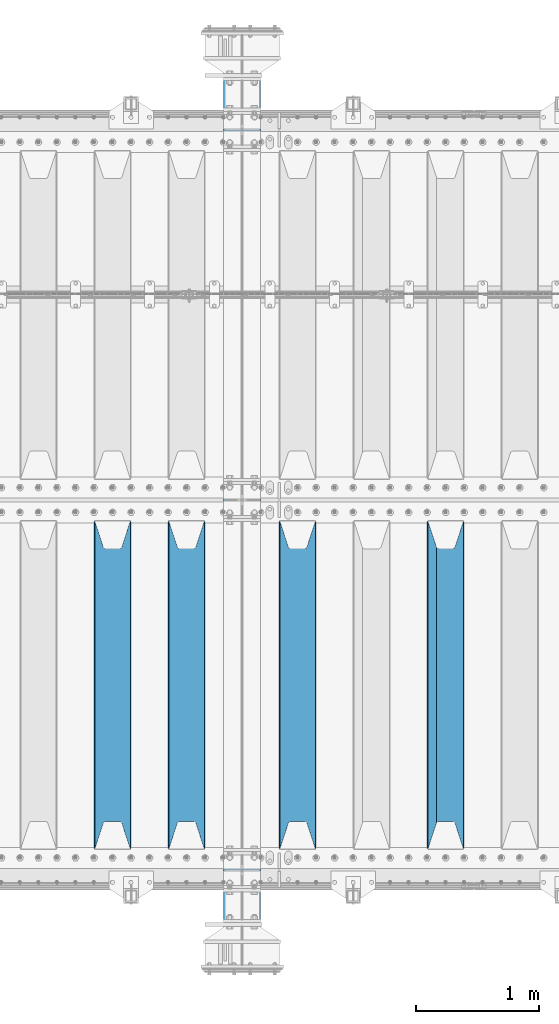
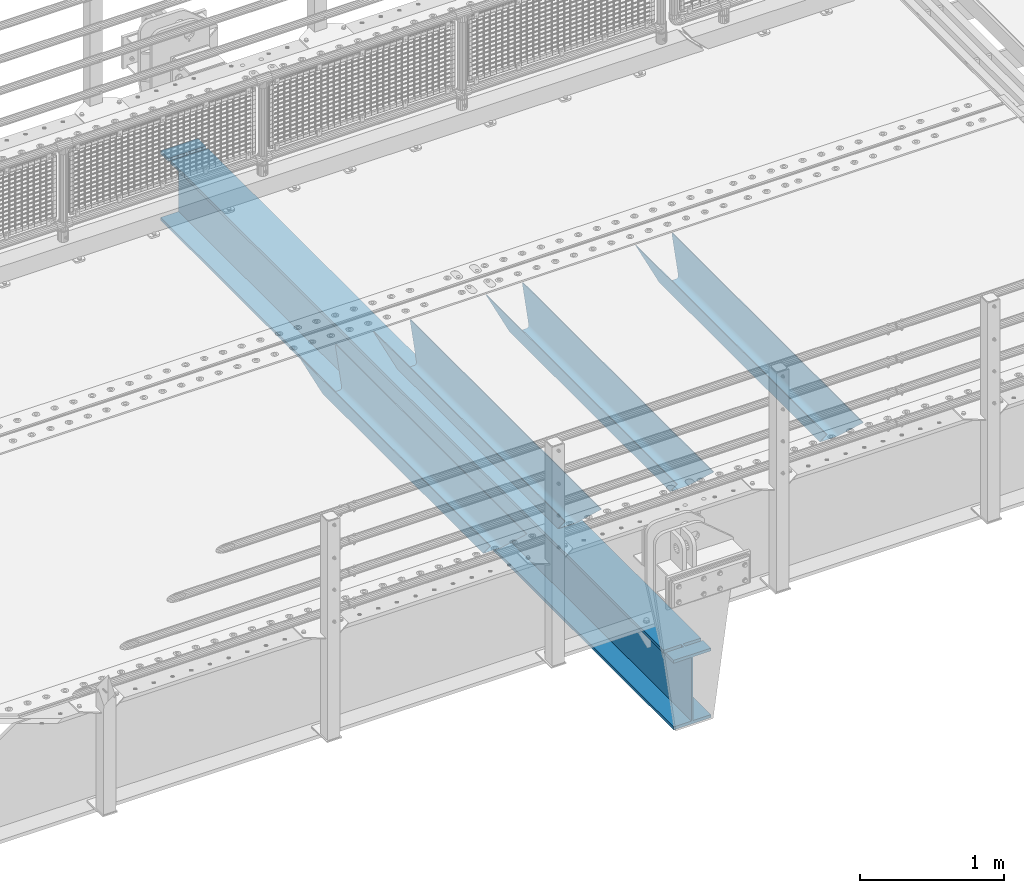
# One storey, part 101 of 208: 5 beams.
"""IFC2X3 building model written with IfcOpenShell, lengths in millimetres."""

from ifc_helpers import new_model, si_unit, frame, origin_with_axes, place, context, subcontext, project, spatial, faceted_brep, material, type_object, element, save


model = new_model("IFC2X3")

# Units and contexts
model_context = context("Model", 3, precision=1e-05, world=origin_with_axes())
body_context = subcontext(model_context, "Body", "Model", "MODEL_VIEW")
ifc_project = project(units=[si_unit("LENGTHUNIT", "METRE", prefix="MILLI"), si_unit("AREAUNIT", "SQUARE_METRE"), si_unit("VOLUMEUNIT", "CUBIC_METRE"), si_unit("MASSUNIT", "GRAM", prefix="KILO"), si_unit("TIMEUNIT", "SECOND"), si_unit("PLANEANGLEUNIT", "RADIAN"), si_unit("SOLIDANGLEUNIT", "STERADIAN"), si_unit("THERMODYNAMICTEMPERATUREUNIT", "DEGREE_CELSIUS"), si_unit("LUMINOUSINTENSITYUNIT", "LUMEN")], contexts=[model_context])

# Site, building, storey
site_placement = place(None, origin_with_axes())
site = spatial("IfcSite", under=ifc_project, at=site_placement, CompositionType="ELEMENT")
building_placement = place(site_placement, origin_with_axes())
building = spatial("IfcBuilding", under=site, at=building_placement, Name="Standard", CompositionType="ELEMENT")
storey_placement = place(building_placement, origin_with_axes())
storey = spatial("IfcBuildingStorey", under=building, at=storey_placement, Name="Undefined", CompositionType="ELEMENT", Elevation=0.0)

# Beams
ifc_material = material(Name="STEEL/S355N")
beam_type_1 = type_object("IfcBeamType", PredefinedType="NOTDEFINED")
beam_1_placement = place(storey_placement, frame((-28550.0, 175.0, -115.0), z_axis=(0.0, 0.0, 1.0), x_axis=(0.0, 1.0, 0.0)))
element("IfcBeam", 1, at=beam_1_placement, inside=storey, type_object=beam_type_1, material=ifc_material, context=body_context, shape_type="Brep", body=[
    faceted_brep([(0.0, 150.0, 115.0), (0.0, 143.689999999999, 115.0), (2650.00000000297, 143.689999999999, 115.0), (2650.00000000297, 150.0, 115.0), (2650.00000000297, 142.059565218402, 110.0000000031), (2650.00000000297, 148.369565218403, 110.0000000031), (2441.90079219208, -80.1103600731112, -98.0992078077845), (2437.7588105432, -77.5672621345584, -102.241189456673), (2434.06523489746, -74.4080125315522, -105.934765102404), (2430.91086095089, -70.710272125576, -109.089139048974), (2428.37322971128, -66.5649389910068, -111.626770288588), (2426.51472138055, -62.0739139532889, -113.485278619323), (2425.38102192091, -57.3475956567672, -114.618978078955), (2424.99999999987, -52.5021667386536, -115.0), (2424.99999999987, 52.5021667386536, -115.0), (2425.38102192091, 57.3475956567672, -114.618978078955), (2426.51472138055, 62.0739139532889, -113.485278619323), (2428.37322971128, 66.5649389910068, -111.626770288588), (2430.91086095089, 70.710272125576, -109.089139048974), (2434.06523489746, 74.4080125315522, -105.934765102404), (2437.7588105432, 77.5672621345584, -102.241189456673), (2441.90079219208, 80.1103600731112, -98.0992078077846), (2446.38936140511, 81.9747917625791, -93.6106385947584), (2448.24948500409, 76.2713538057251, -91.7505149957729), (2444.62967112262, 74.76777986261, -95.3703288772456), (2441.28936334126, 72.7168944282894, -98.710636658607), (2438.31067330438, 70.1691124903846, -101.689326695487), (2435.76682334747, 67.1870637758839, -104.233176652398), (2433.72034654133, 63.8440531834895, -106.279653458539), (2432.22154950041, 60.222258798236, -107.778450499454), (2431.30727574265, 56.4107117849089, -108.692724257221), (2430.99999999987, 52.5031078186876, -109.0), (2430.99999999987, -52.5031078186876, -109.0), (2431.30727574265, -56.4107117849089, -108.692724257221), (2432.22154950041, -60.222258798236, -107.778450499454), (2433.72034654133, -63.8440531834895, -106.279653458539), (2435.76682334747, -67.1870637758839, -104.233176652398), (2438.31067330438, -70.1691124903846, -101.689326695487), (2441.28936334126, -72.7168944282894, -98.7106366586071), (2444.62967112262, -74.76777986261, -95.3703288772457), (2448.24948500409, -76.2713538057251, -91.7505149957729), (2650.00000000297, -142.059565218402, 110.0000000031), (2650.00000000297, -148.369565218403, 110.0000000031), (2446.38936140511, -81.9747917625791, -93.6106385947584), (2650.00000000297, -143.689999999999, 115.0), (2650.00000000297, -150.0, 115.0), (0.0, -143.689999999999, 115.0), (0.0, -150.0, 115.0), (0.0, -148.369565218261, 110.000000002663), (203.610638597421, -81.9747917625791, -93.6106385947584), (208.099207810448, -80.1103600731112, -98.0992078077845), (212.241189459336, -77.5672621345584, -102.241189456673), (215.934765105067, -74.4080125315522, -105.934765102404), (219.089139051637, -70.710272125576, -109.089139048974), (221.626770291251, -66.5649389910068, -111.626770288588), (223.485278621986, -62.0739139532889, -113.485278619323), (224.618978081618, -57.3475956567672, -114.618978078955), (225.000000002663, -52.5021667386536, -115.0), (225.000000002663, 52.5021667386536, -115.0), (224.618978081618, 57.3475956567672, -114.618978078955), (223.485278621986, 62.0739139532889, -113.485278619323), (221.626770291251, 66.5649389910068, -111.626770288588), (219.089139051637, 70.710272125576, -109.089139048974), (215.934765105067, 74.4080125315522, -105.934765102404), (212.241189459336, 77.5672621345584, -102.241189456673), (208.099207810448, 80.1103600731112, -98.0992078077846), (203.610638597421, 81.9747917625791, -93.6106385947584), (0.0, 148.369565218261, 110.000000002663), (0.0, 142.05956521826, 110.000000002663), (201.750514998436, 76.2713538057251, -91.7505149957729), (205.370328879908, 74.76777986261, -95.3703288772456), (208.71063666127, 72.7168944282894, -98.710636658607), (211.68932669815, 70.1691124903846, -101.689326695487), (214.233176655061, 67.1870637758839, -104.233176652398), (216.279653461202, 63.8440531834895, -106.279653458539), (217.778450502116, 60.222258798236, -107.778450499454), (218.692724259884, 56.4107117849089, -108.692724257221), (219.000000002663, 52.5031078186876, -109.0), (219.000000002663, -52.5031078186876, -109.0), (218.692724259884, -56.4107117849089, -108.692724257221), (217.778450502116, -60.222258798236, -107.778450499454), (216.279653461202, -63.8440531834895, -106.279653458539), (214.233176655061, -67.1870637758839, -104.233176652398), (211.68932669815, -70.1691124903846, -101.689326695487), (208.71063666127, -72.7168944282894, -98.7106366586071), (205.370328879908, -74.76777986261, -95.3703288772457), (201.750514998436, -76.2713538057251, -91.7505149957729), (0.0, -142.05956521826, 110.000000002663)], [[[0, 1, 2, 3]], [[3, 2, 4, 5]], [[6, 7, 8, 9, 10, 11, 12, 13, 14, 15, 16, 17, 18, 19, 20, 21, 22, 5, 4, 23, 24, 25, 26, 27, 28, 29, 30, 31, 32, 33, 34, 35, 36, 37, 38, 39, 40, 41, 42, 43]], [[44, 45, 42, 41]], [[46, 47, 45, 44]], [[43, 42, 45, 47, 48, 49]], [[6, 43, 49, 50]], [[7, 6, 50, 51]], [[8, 7, 51, 52]], [[9, 8, 52, 53]], [[10, 9, 53, 54]], [[11, 10, 54, 55]], [[12, 11, 55, 56]], [[13, 12, 56, 57]], [[14, 13, 57, 58]], [[15, 14, 58, 59]], [[16, 15, 59, 60]], [[17, 16, 60, 61]], [[18, 17, 61, 62]], [[19, 18, 62, 63]], [[20, 19, 63, 64]], [[21, 20, 64, 65]], [[22, 21, 65, 66]], [[0, 3, 5, 22, 66, 67]], [[1, 0, 67, 68]], [[23, 4, 2, 1, 68, 69]], [[24, 23, 69, 70]], [[25, 24, 70, 71]], [[26, 25, 71, 72]], [[27, 26, 72, 73]], [[28, 27, 73, 74]], [[29, 28, 74, 75]], [[30, 29, 75, 76]], [[31, 30, 76, 77]], [[32, 31, 77, 78]], [[33, 32, 78, 79]], [[34, 33, 79, 80]], [[35, 34, 80, 81]], [[36, 35, 81, 82]], [[37, 36, 82, 83]], [[38, 37, 83, 84]], [[39, 38, 84, 85]], [[40, 39, 85, 86]], [[46, 44, 41, 40, 86, 87]], [[47, 46, 87, 48]], [[86, 85, 84, 83, 82, 81, 80, 79, 78, 77, 76, 75, 74, 73, 72, 71, 70, 69, 68, 67, 66, 65, 64, 63, 62, 61, 60, 59, 58, 57, 56, 55, 54, 53, 52, 51, 50, 49, 48, 87]]]),
])
beam_2_placement = place(storey_placement, frame((-29750.0, 175.0, -115.0), z_axis=(0.0, 0.0, 1.0), x_axis=(0.0, 1.0, 0.0)))
element("IfcBeam", 2, at=beam_2_placement, inside=storey, type_object=beam_type_1, material=ifc_material, context=body_context, shape_type="Brep", body=[
    faceted_brep([(0.0, 150.0, 115.0), (0.0, 143.689999999999, 115.0), (2650.00000000297, 143.689999999999, 115.0), (2650.00000000297, 150.0, 115.0), (2650.00000000297, 142.059565218402, 110.0000000031), (2650.00000000297, 148.369565218403, 110.0000000031), (2441.90079219208, -80.1103600731112, -98.0992078077845), (2437.7588105432, -77.5672621345584, -102.241189456673), (2434.06523489746, -74.4080125315522, -105.934765102404), (2430.91086095089, -70.710272125576, -109.089139048974), (2428.37322971128, -66.5649389910068, -111.626770288588), (2426.51472138055, -62.0739139532889, -113.485278619323), (2425.38102192091, -57.3475956567672, -114.618978078955), (2424.99999999987, -52.5021667386536, -115.0), (2424.99999999987, 52.5021667386536, -115.0), (2425.38102192091, 57.3475956567672, -114.618978078955), (2426.51472138055, 62.0739139532889, -113.485278619323), (2428.37322971128, 66.5649389910068, -111.626770288588), (2430.91086095089, 70.710272125576, -109.089139048974), (2434.06523489746, 74.4080125315522, -105.934765102404), (2437.7588105432, 77.5672621345584, -102.241189456673), (2441.90079219208, 80.1103600731112, -98.0992078077846), (2446.38936140511, 81.9747917625791, -93.6106385947584), (2448.24948500409, 76.2713538057251, -91.7505149957729), (2444.62967112262, 74.76777986261, -95.3703288772456), (2441.28936334126, 72.7168944282894, -98.710636658607), (2438.31067330438, 70.1691124903846, -101.689326695487), (2435.76682334747, 67.1870637758839, -104.233176652398), (2433.72034654133, 63.8440531834895, -106.279653458539), (2432.22154950041, 60.222258798236, -107.778450499454), (2431.30727574265, 56.4107117849089, -108.692724257221), (2430.99999999987, 52.5031078186876, -109.0), (2430.99999999987, -52.5031078186876, -109.0), (2431.30727574265, -56.4107117849089, -108.692724257221), (2432.22154950041, -60.222258798236, -107.778450499454), (2433.72034654133, -63.8440531834895, -106.279653458539), (2435.76682334747, -67.1870637758839, -104.233176652398), (2438.31067330438, -70.1691124903846, -101.689326695487), (2441.28936334126, -72.7168944282894, -98.7106366586071), (2444.62967112262, -74.76777986261, -95.3703288772457), (2448.24948500409, -76.2713538057251, -91.7505149957729), (2650.00000000297, -142.059565218402, 110.0000000031), (2650.00000000297, -148.369565218403, 110.0000000031), (2446.38936140511, -81.9747917625791, -93.6106385947584), (2650.00000000297, -143.689999999999, 115.0), (2650.00000000297, -150.0, 115.0), (0.0, -143.689999999999, 115.0), (0.0, -150.0, 115.0), (0.0, -148.369565218261, 110.000000002663), (203.610638597421, -81.9747917625791, -93.6106385947584), (208.099207810448, -80.1103600731112, -98.0992078077845), (212.241189459336, -77.5672621345584, -102.241189456673), (215.934765105067, -74.4080125315522, -105.934765102404), (219.089139051637, -70.710272125576, -109.089139048974), (221.626770291251, -66.5649389910068, -111.626770288588), (223.485278621986, -62.0739139532889, -113.485278619323), (224.618978081618, -57.3475956567672, -114.618978078955), (225.000000002663, -52.5021667386536, -115.0), (225.000000002663, 52.5021667386536, -115.0), (224.618978081618, 57.3475956567672, -114.618978078955), (223.485278621986, 62.0739139532889, -113.485278619323), (221.626770291251, 66.5649389910068, -111.626770288588), (219.089139051637, 70.710272125576, -109.089139048974), (215.934765105067, 74.4080125315522, -105.934765102404), (212.241189459336, 77.5672621345584, -102.241189456673), (208.099207810448, 80.1103600731112, -98.0992078077846), (203.610638597421, 81.9747917625791, -93.6106385947584), (0.0, 148.369565218261, 110.000000002663), (0.0, 142.05956521826, 110.000000002663), (201.750514998436, 76.2713538057251, -91.7505149957729), (205.370328879908, 74.76777986261, -95.3703288772456), (208.71063666127, 72.7168944282894, -98.710636658607), (211.68932669815, 70.1691124903846, -101.689326695487), (214.233176655061, 67.1870637758839, -104.233176652398), (216.279653461202, 63.8440531834895, -106.279653458539), (217.778450502116, 60.222258798236, -107.778450499454), (218.692724259884, 56.4107117849089, -108.692724257221), (219.000000002663, 52.5031078186876, -109.0), (219.000000002663, -52.5031078186876, -109.0), (218.692724259884, -56.4107117849089, -108.692724257221), (217.778450502116, -60.222258798236, -107.778450499454), (216.279653461202, -63.8440531834895, -106.279653458539), (214.233176655061, -67.1870637758839, -104.233176652398), (211.68932669815, -70.1691124903846, -101.689326695487), (208.71063666127, -72.7168944282894, -98.7106366586071), (205.370328879908, -74.76777986261, -95.3703288772457), (201.750514998436, -76.2713538057251, -91.7505149957729), (0.0, -142.05956521826, 110.000000002663)], [[[0, 1, 2, 3]], [[3, 2, 4, 5]], [[6, 7, 8, 9, 10, 11, 12, 13, 14, 15, 16, 17, 18, 19, 20, 21, 22, 5, 4, 23, 24, 25, 26, 27, 28, 29, 30, 31, 32, 33, 34, 35, 36, 37, 38, 39, 40, 41, 42, 43]], [[44, 45, 42, 41]], [[46, 47, 45, 44]], [[43, 42, 45, 47, 48, 49]], [[6, 43, 49, 50]], [[7, 6, 50, 51]], [[8, 7, 51, 52]], [[9, 8, 52, 53]], [[10, 9, 53, 54]], [[11, 10, 54, 55]], [[12, 11, 55, 56]], [[13, 12, 56, 57]], [[14, 13, 57, 58]], [[15, 14, 58, 59]], [[16, 15, 59, 60]], [[17, 16, 60, 61]], [[18, 17, 61, 62]], [[19, 18, 62, 63]], [[20, 19, 63, 64]], [[21, 20, 64, 65]], [[22, 21, 65, 66]], [[0, 3, 5, 22, 66, 67]], [[1, 0, 67, 68]], [[23, 4, 2, 1, 68, 69]], [[24, 23, 69, 70]], [[25, 24, 70, 71]], [[26, 25, 71, 72]], [[27, 26, 72, 73]], [[28, 27, 73, 74]], [[29, 28, 74, 75]], [[30, 29, 75, 76]], [[31, 30, 76, 77]], [[32, 31, 77, 78]], [[33, 32, 78, 79]], [[34, 33, 79, 80]], [[35, 34, 80, 81]], [[36, 35, 81, 82]], [[37, 36, 82, 83]], [[38, 37, 83, 84]], [[39, 38, 84, 85]], [[40, 39, 85, 86]], [[46, 44, 41, 40, 86, 87]], [[47, 46, 87, 48]], [[86, 85, 84, 83, 82, 81, 80, 79, 78, 77, 76, 75, 74, 73, 72, 71, 70, 69, 68, 67, 66, 65, 64, 63, 62, 61, 60, 59, 58, 57, 56, 55, 54, 53, 52, 51, 50, 49, 48, 87]]]),
])
beam_3_placement = place(storey_placement, frame((-30650.0, 175.0, -115.0), z_axis=(0.0, 0.0, 1.0), x_axis=(0.0, 1.0, 0.0)))
element("IfcBeam", 3, at=beam_3_placement, inside=storey, type_object=beam_type_1, material=ifc_material, context=body_context, shape_type="Brep", body=[
    faceted_brep([(0.0, 150.0, 115.0), (0.0, 143.689999999999, 115.0), (2650.00000000297, 143.689999999999, 115.0), (2650.00000000297, 150.0, 115.0), (2650.00000000297, 142.059565218402, 110.0000000031), (2650.00000000297, 148.369565218403, 110.0000000031), (2441.90079219208, -80.1103600731112, -98.0992078077845), (2437.7588105432, -77.5672621345584, -102.241189456673), (2434.06523489746, -74.4080125315522, -105.934765102404), (2430.91086095089, -70.710272125576, -109.089139048974), (2428.37322971128, -66.5649389910068, -111.626770288588), (2426.51472138055, -62.0739139532889, -113.485278619323), (2425.38102192091, -57.3475956567672, -114.618978078955), (2424.99999999987, -52.5021667386536, -115.0), (2424.99999999987, 52.5021667386536, -115.0), (2425.38102192091, 57.3475956567672, -114.618978078955), (2426.51472138055, 62.0739139532889, -113.485278619323), (2428.37322971128, 66.5649389910068, -111.626770288588), (2430.91086095089, 70.710272125576, -109.089139048974), (2434.06523489746, 74.4080125315522, -105.934765102404), (2437.7588105432, 77.5672621345584, -102.241189456673), (2441.90079219208, 80.1103600731112, -98.0992078077846), (2446.38936140511, 81.9747917625791, -93.6106385947584), (2448.24948500409, 76.2713538057251, -91.7505149957729), (2444.62967112262, 74.76777986261, -95.3703288772456), (2441.28936334126, 72.7168944282894, -98.710636658607), (2438.31067330438, 70.1691124903846, -101.689326695487), (2435.76682334747, 67.1870637758839, -104.233176652398), (2433.72034654133, 63.8440531834895, -106.279653458539), (2432.22154950041, 60.222258798236, -107.778450499454), (2431.30727574265, 56.4107117849089, -108.692724257221), (2430.99999999987, 52.5031078186876, -109.0), (2430.99999999987, -52.5031078186876, -109.0), (2431.30727574265, -56.4107117849089, -108.692724257221), (2432.22154950041, -60.222258798236, -107.778450499454), (2433.72034654133, -63.8440531834895, -106.279653458539), (2435.76682334747, -67.1870637758839, -104.233176652398), (2438.31067330438, -70.1691124903846, -101.689326695487), (2441.28936334126, -72.7168944282894, -98.7106366586071), (2444.62967112262, -74.76777986261, -95.3703288772457), (2448.24948500409, -76.2713538057251, -91.7505149957729), (2650.00000000297, -142.059565218402, 110.0000000031), (2650.00000000297, -148.369565218403, 110.0000000031), (2446.38936140511, -81.9747917625791, -93.6106385947584), (2650.00000000297, -143.689999999999, 115.0), (2650.00000000297, -150.0, 115.0), (0.0, -143.689999999999, 115.0), (0.0, -150.0, 115.0), (0.0, -148.369565218261, 110.000000002663), (203.610638597421, -81.9747917625791, -93.6106385947584), (208.099207810448, -80.1103600731112, -98.0992078077845), (212.241189459336, -77.5672621345584, -102.241189456673), (215.934765105067, -74.4080125315522, -105.934765102404), (219.089139051637, -70.710272125576, -109.089139048974), (221.626770291251, -66.5649389910068, -111.626770288588), (223.485278621986, -62.0739139532889, -113.485278619323), (224.618978081618, -57.3475956567672, -114.618978078955), (225.000000002663, -52.5021667386536, -115.0), (225.000000002663, 52.5021667386536, -115.0), (224.618978081618, 57.3475956567672, -114.618978078955), (223.485278621986, 62.0739139532889, -113.485278619323), (221.626770291251, 66.5649389910068, -111.626770288588), (219.089139051637, 70.710272125576, -109.089139048974), (215.934765105067, 74.4080125315522, -105.934765102404), (212.241189459336, 77.5672621345584, -102.241189456673), (208.099207810448, 80.1103600731112, -98.0992078077846), (203.610638597421, 81.9747917625791, -93.6106385947584), (0.0, 148.369565218261, 110.000000002663), (0.0, 142.05956521826, 110.000000002663), (201.750514998436, 76.2713538057251, -91.7505149957729), (205.370328879908, 74.76777986261, -95.3703288772456), (208.71063666127, 72.7168944282894, -98.710636658607), (211.68932669815, 70.1691124903846, -101.689326695487), (214.233176655061, 67.1870637758839, -104.233176652398), (216.279653461202, 63.8440531834895, -106.279653458539), (217.778450502116, 60.222258798236, -107.778450499454), (218.692724259884, 56.4107117849089, -108.692724257221), (219.000000002663, 52.5031078186876, -109.0), (219.000000002663, -52.5031078186876, -109.0), (218.692724259884, -56.4107117849089, -108.692724257221), (217.778450502116, -60.222258798236, -107.778450499454), (216.279653461202, -63.8440531834895, -106.279653458539), (214.233176655061, -67.1870637758839, -104.233176652398), (211.68932669815, -70.1691124903846, -101.689326695487), (208.71063666127, -72.7168944282894, -98.7106366586071), (205.370328879908, -74.76777986261, -95.3703288772457), (201.750514998436, -76.2713538057251, -91.7505149957729), (0.0, -142.05956521826, 110.000000002663)], [[[0, 1, 2, 3]], [[3, 2, 4, 5]], [[6, 7, 8, 9, 10, 11, 12, 13, 14, 15, 16, 17, 18, 19, 20, 21, 22, 5, 4, 23, 24, 25, 26, 27, 28, 29, 30, 31, 32, 33, 34, 35, 36, 37, 38, 39, 40, 41, 42, 43]], [[44, 45, 42, 41]], [[46, 47, 45, 44]], [[43, 42, 45, 47, 48, 49]], [[6, 43, 49, 50]], [[7, 6, 50, 51]], [[8, 7, 51, 52]], [[9, 8, 52, 53]], [[10, 9, 53, 54]], [[11, 10, 54, 55]], [[12, 11, 55, 56]], [[13, 12, 56, 57]], [[14, 13, 57, 58]], [[15, 14, 58, 59]], [[16, 15, 59, 60]], [[17, 16, 60, 61]], [[18, 17, 61, 62]], [[19, 18, 62, 63]], [[20, 19, 63, 64]], [[21, 20, 64, 65]], [[22, 21, 65, 66]], [[0, 3, 5, 22, 66, 67]], [[1, 0, 67, 68]], [[23, 4, 2, 1, 68, 69]], [[24, 23, 69, 70]], [[25, 24, 70, 71]], [[26, 25, 71, 72]], [[27, 26, 72, 73]], [[28, 27, 73, 74]], [[29, 28, 74, 75]], [[30, 29, 75, 76]], [[31, 30, 76, 77]], [[32, 31, 77, 78]], [[33, 32, 78, 79]], [[34, 33, 79, 80]], [[35, 34, 80, 81]], [[36, 35, 81, 82]], [[37, 36, 82, 83]], [[38, 37, 83, 84]], [[39, 38, 84, 85]], [[40, 39, 85, 86]], [[46, 44, 41, 40, 86, 87]], [[47, 46, 87, 48]], [[86, 85, 84, 83, 82, 81, 80, 79, 78, 77, 76, 75, 74, 73, 72, 71, 70, 69, 68, 67, 66, 65, 64, 63, 62, 61, 60, 59, 58, 57, 56, 55, 54, 53, 52, 51, 50, 49, 48, 87]]]),
])
beam_4_placement = place(storey_placement, frame((-31250.0, 175.0, -115.0), z_axis=(0.0, 0.0, 1.0), x_axis=(0.0, 1.0, 0.0)))
element("IfcBeam", 4, at=beam_4_placement, inside=storey, type_object=beam_type_1, material=ifc_material, context=body_context, shape_type="Brep", body=[
    faceted_brep([(0.0, 150.0, 115.0), (0.0, 143.689999999999, 115.0), (2650.00000000297, 143.689999999999, 115.0), (2650.00000000297, 150.0, 115.0), (2650.00000000297, 142.059565218402, 110.0000000031), (2650.00000000297, 148.369565218403, 110.0000000031), (2441.90079219208, -80.1103600731112, -98.0992078077845), (2437.7588105432, -77.5672621345584, -102.241189456673), (2434.06523489746, -74.4080125315522, -105.934765102404), (2430.91086095089, -70.710272125576, -109.089139048974), (2428.37322971128, -66.5649389910068, -111.626770288588), (2426.51472138055, -62.0739139532889, -113.485278619323), (2425.38102192091, -57.3475956567672, -114.618978078955), (2424.99999999987, -52.5021667386536, -115.0), (2424.99999999987, 52.5021667386536, -115.0), (2425.38102192091, 57.3475956567672, -114.618978078955), (2426.51472138055, 62.0739139532889, -113.485278619323), (2428.37322971128, 66.5649389910068, -111.626770288588), (2430.91086095089, 70.710272125576, -109.089139048974), (2434.06523489746, 74.4080125315522, -105.934765102404), (2437.7588105432, 77.5672621345584, -102.241189456673), (2441.90079219208, 80.1103600731112, -98.0992078077846), (2446.38936140511, 81.9747917625791, -93.6106385947584), (2448.24948500409, 76.2713538057251, -91.7505149957729), (2444.62967112262, 74.76777986261, -95.3703288772456), (2441.28936334126, 72.7168944282894, -98.710636658607), (2438.31067330438, 70.1691124903846, -101.689326695487), (2435.76682334747, 67.1870637758839, -104.233176652398), (2433.72034654133, 63.8440531834895, -106.279653458539), (2432.22154950041, 60.222258798236, -107.778450499454), (2431.30727574265, 56.4107117849089, -108.692724257221), (2430.99999999987, 52.5031078186876, -109.0), (2430.99999999987, -52.5031078186876, -109.0), (2431.30727574265, -56.4107117849089, -108.692724257221), (2432.22154950041, -60.222258798236, -107.778450499454), (2433.72034654133, -63.8440531834895, -106.279653458539), (2435.76682334747, -67.1870637758839, -104.233176652398), (2438.31067330438, -70.1691124903846, -101.689326695487), (2441.28936334126, -72.7168944282894, -98.7106366586071), (2444.62967112262, -74.76777986261, -95.3703288772457), (2448.24948500409, -76.2713538057251, -91.7505149957729), (2650.00000000297, -142.059565218402, 110.0000000031), (2650.00000000297, -148.369565218403, 110.0000000031), (2446.38936140511, -81.9747917625791, -93.6106385947584), (2650.00000000297, -143.689999999999, 115.0), (2650.00000000297, -150.0, 115.0), (0.0, -143.689999999999, 115.0), (0.0, -150.0, 115.0), (0.0, -148.369565218261, 110.000000002663), (203.610638597421, -81.9747917625791, -93.6106385947584), (208.099207810448, -80.1103600731112, -98.0992078077845), (212.241189459336, -77.5672621345584, -102.241189456673), (215.934765105067, -74.4080125315522, -105.934765102404), (219.089139051637, -70.710272125576, -109.089139048974), (221.626770291251, -66.5649389910068, -111.626770288588), (223.485278621986, -62.0739139532889, -113.485278619323), (224.618978081618, -57.3475956567672, -114.618978078955), (225.000000002663, -52.5021667386536, -115.0), (225.000000002663, 52.5021667386536, -115.0), (224.618978081618, 57.3475956567672, -114.618978078955), (223.485278621986, 62.0739139532889, -113.485278619323), (221.626770291251, 66.5649389910068, -111.626770288588), (219.089139051637, 70.710272125576, -109.089139048974), (215.934765105067, 74.4080125315522, -105.934765102404), (212.241189459336, 77.5672621345584, -102.241189456673), (208.099207810448, 80.1103600731112, -98.0992078077846), (203.610638597421, 81.9747917625791, -93.6106385947584), (0.0, 148.369565218261, 110.000000002663), (0.0, 142.05956521826, 110.000000002663), (201.750514998436, 76.2713538057251, -91.7505149957729), (205.370328879908, 74.76777986261, -95.3703288772456), (208.71063666127, 72.7168944282894, -98.710636658607), (211.68932669815, 70.1691124903846, -101.689326695487), (214.233176655061, 67.1870637758839, -104.233176652398), (216.279653461202, 63.8440531834895, -106.279653458539), (217.778450502116, 60.222258798236, -107.778450499454), (218.692724259884, 56.4107117849089, -108.692724257221), (219.000000002663, 52.5031078186876, -109.0), (219.000000002663, -52.5031078186876, -109.0), (218.692724259884, -56.4107117849089, -108.692724257221), (217.778450502116, -60.222258798236, -107.778450499454), (216.279653461202, -63.8440531834895, -106.279653458539), (214.233176655061, -67.1870637758839, -104.233176652398), (211.68932669815, -70.1691124903846, -101.689326695487), (208.71063666127, -72.7168944282894, -98.7106366586071), (205.370328879908, -74.76777986261, -95.3703288772457), (201.750514998436, -76.2713538057251, -91.7505149957729), (0.0, -142.05956521826, 110.000000002663)], [[[0, 1, 2, 3]], [[3, 2, 4, 5]], [[6, 7, 8, 9, 10, 11, 12, 13, 14, 15, 16, 17, 18, 19, 20, 21, 22, 5, 4, 23, 24, 25, 26, 27, 28, 29, 30, 31, 32, 33, 34, 35, 36, 37, 38, 39, 40, 41, 42, 43]], [[44, 45, 42, 41]], [[46, 47, 45, 44]], [[43, 42, 45, 47, 48, 49]], [[6, 43, 49, 50]], [[7, 6, 50, 51]], [[8, 7, 51, 52]], [[9, 8, 52, 53]], [[10, 9, 53, 54]], [[11, 10, 54, 55]], [[12, 11, 55, 56]], [[13, 12, 56, 57]], [[14, 13, 57, 58]], [[15, 14, 58, 59]], [[16, 15, 59, 60]], [[17, 16, 60, 61]], [[18, 17, 61, 62]], [[19, 18, 62, 63]], [[20, 19, 63, 64]], [[21, 20, 64, 65]], [[22, 21, 65, 66]], [[0, 3, 5, 22, 66, 67]], [[1, 0, 67, 68]], [[23, 4, 2, 1, 68, 69]], [[24, 23, 69, 70]], [[25, 24, 70, 71]], [[26, 25, 71, 72]], [[27, 26, 72, 73]], [[28, 27, 73, 74]], [[29, 28, 74, 75]], [[30, 29, 75, 76]], [[31, 30, 76, 77]], [[32, 31, 77, 78]], [[33, 32, 78, 79]], [[34, 33, 79, 80]], [[35, 34, 80, 81]], [[36, 35, 81, 82]], [[37, 36, 82, 83]], [[38, 37, 83, 84]], [[39, 38, 84, 85]], [[40, 39, 85, 86]], [[46, 44, 41, 40, 86, 87]], [[47, 46, 87, 48]], [[86, 85, 84, 83, 82, 81, 80, 79, 78, 77, 76, 75, 74, 73, 72, 71, 70, 69, 68, 67, 66, 65, 64, 63, 62, 61, 60, 59, 58, 57, 56, 55, 54, 53, 52, 51, 50, 49, 48, 87]]]),
])
beam_type_2 = type_object("IfcBeamType", Name="HEA600", PredefinedType="NOTDEFINED")
beam_5_placement = place(storey_placement, frame((-30200.0000001802, -564.999999964948, -1185.00001822199), z_axis=(0.0, 0.0, 1.0), x_axis=(0.0, 1.0, 0.0)))
element("IfcBeam", 5, at=beam_5_placement, inside=storey, type_object=beam_type_2, material=ifc_material, ObjectType="HEA600", context=body_context, shape_type="Brep", body=[
    faceted_brep([(6989.99999999952, -150.000000004802, 295.0), (6989.99999999952, -150.0, 270.0), (6989.99999999952, -6.5, 270.0), (6989.99999999952, -6.5, 295.0), (7019.99999999952, -6.5, 270.0), (7019.99999999952, -6.5, 295.0), (7019.99999999952, -150.0, 295.0), (7019.99999999952, -150.0, 270.0), (7129.99999999952, -150.0, 270.0), (7129.99999999952, -150.0, 295.0), (7129.99999999952, -6.5, 270.0), (7129.99999999952, 150.0, 295.0), (7129.99999999952, 150.0, 270.0), (7019.99999999952, 150.0, 270.0), (7019.99999999952, 150.0, 295.0), (140.000000044317, 6.5, 270.0), (140.000000324838, 150.0, 270.0), (6989.99999999952, 150.0, 270.0), (6989.99999999952, 6.5, 270.0), (0.0, -150.0, -295.0), (0.0, 150.0, -295.0), (7129.99999999952, 150.0, -295.0), (7129.99999999952, -150.0, -295.0), (7019.99999999952, -150.0, -270.0), (6989.99999999952, -150.0, -270.0), (139.999999738288, -150.0, -270.0), (109.999999738287, -150.0, -270.0), (0.0, -150.0, -270.0), (7129.99999999952, -150.0, -270.0), (7019.99999999952, -6.5, -270.0), (6989.99999999952, -6.5, -270.0), (140.000000025126, -6.5, -270.0), (110.000000025288, -6.5, -270.0), (0.0, -6.5, -270.0), (7129.99999999952, -6.5, -270.0), (0.0, -150.0, 270.0), (0.0, -6.5, 270.0), (110.000000025287, -6.5, 270.0), (109.999999738287, -150.0, 270.0), (139.999999738288, -150.00000023983, 295.0), (140.000000025126, -6.50000023983011, 295.0), (140.000000025126, -6.5, 270.0), (139.999999738288, -150.0, 270.0), (110.000000025288, -6.50000017982893, 295.0), (109.999999738287, -150.0, 295.0), (0.0, -150.0, 295.0), (0.0, 6.5, 270.0), (0.0, 150.0, 270.0), (110.000000324838, 150.0, 270.0), (110.000000324838, 6.5, 270.0), (0.0, 150.0, 295.0), (0.0, 6.5, -270.0), (0.0, 150.0, -270.0), (110.000000324838, 150.0, 295.0), (110.000000324838, 6.49999976097024, 295.0), (140.000000044317, 6.49999976097024, 295.0), (140.000000324838, 150.0, 295.0), (6989.99999999952, 150.0, 295.0), (6989.99999999952, 6.5, 295.0), (7019.99999999952, 6.5, 295.0), (7019.99999999952, 6.5, 270.0), (7129.99999999952, 6.5, 270.0), (7019.99999999952, 6.5, -270.0), (6989.99999999952, 6.5, -270.0), (140.000000044317, 6.5, -270.0), (110.000000324838, 6.5, -270.0), (7129.99999999952, 6.5, -270.0), (7019.99999999952, 150.0, -270.0), (6989.99999999952, 150.0, -270.0), (140.000000324839, 150.0, -270.0), (110.000000324838, 150.0, -270.0), (7129.99999999952, 150.0, -270.0)], [[[0, 1, 2, 3]], [[3, 2, 4, 5]], [[6, 5, 4, 7]], [[8, 9, 6, 7]], [[10, 8, 7, 4]], [[11, 12, 13, 14]], [[15, 16, 17, 18]], [[19, 20, 21, 22]], [[23, 24, 25, 26, 27, 19, 22, 28]], [[29, 30, 31, 32, 33, 27, 26, 25, 24, 23, 28, 34]], [[35, 36, 37, 38]], [[39, 40, 41, 42]], [[43, 37, 41, 40]], [[44, 38, 37, 43]], [[45, 35, 38, 44]], [[46, 47, 48, 49]], [[19, 27, 33, 36, 35, 45, 50, 47, 46, 51, 52, 20]], [[47, 50, 53, 48]], [[54, 49, 48, 53]], [[55, 15, 49, 54]], [[56, 16, 15, 55]], [[16, 56, 57, 17]], [[58, 18, 17, 57]], [[59, 60, 18, 58]], [[14, 13, 60, 59]], [[12, 61, 60, 13]], [[62, 63, 64, 65, 51, 46, 49, 15, 18, 60, 61, 66]], [[67, 68, 69, 70, 52, 51, 65, 64, 63, 62, 66, 71]], [[20, 52, 70, 69, 68, 67, 71, 21]], [[66, 61, 12, 11, 9, 8, 10, 34, 28, 22, 21, 71]], [[4, 2, 41, 37, 36, 33, 32, 31, 30, 29, 34, 10]], [[42, 41, 2, 1]], [[39, 42, 1, 0]], [[9, 11, 14, 59, 58, 57, 56, 55, 54, 53, 50, 45, 44, 43, 40, 39, 0, 3, 5, 6]]]),
])

save(model, "model.ifc")
